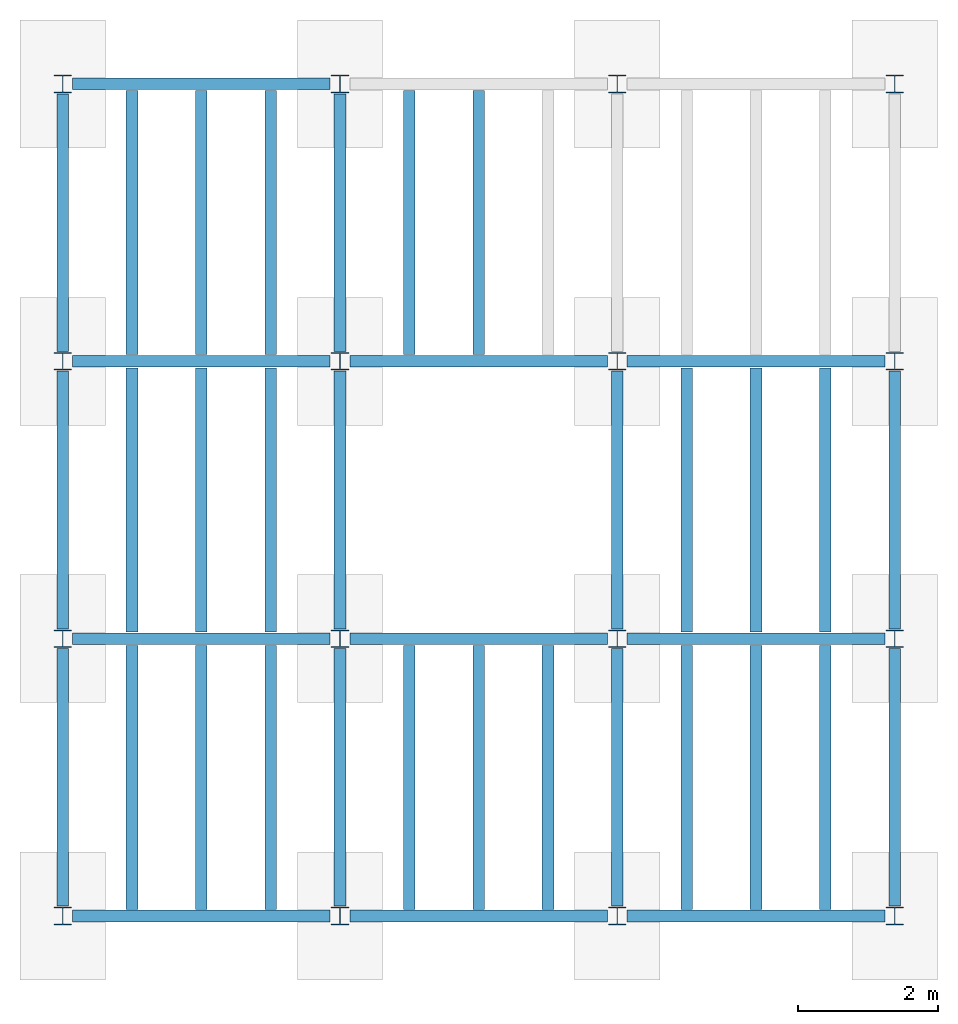
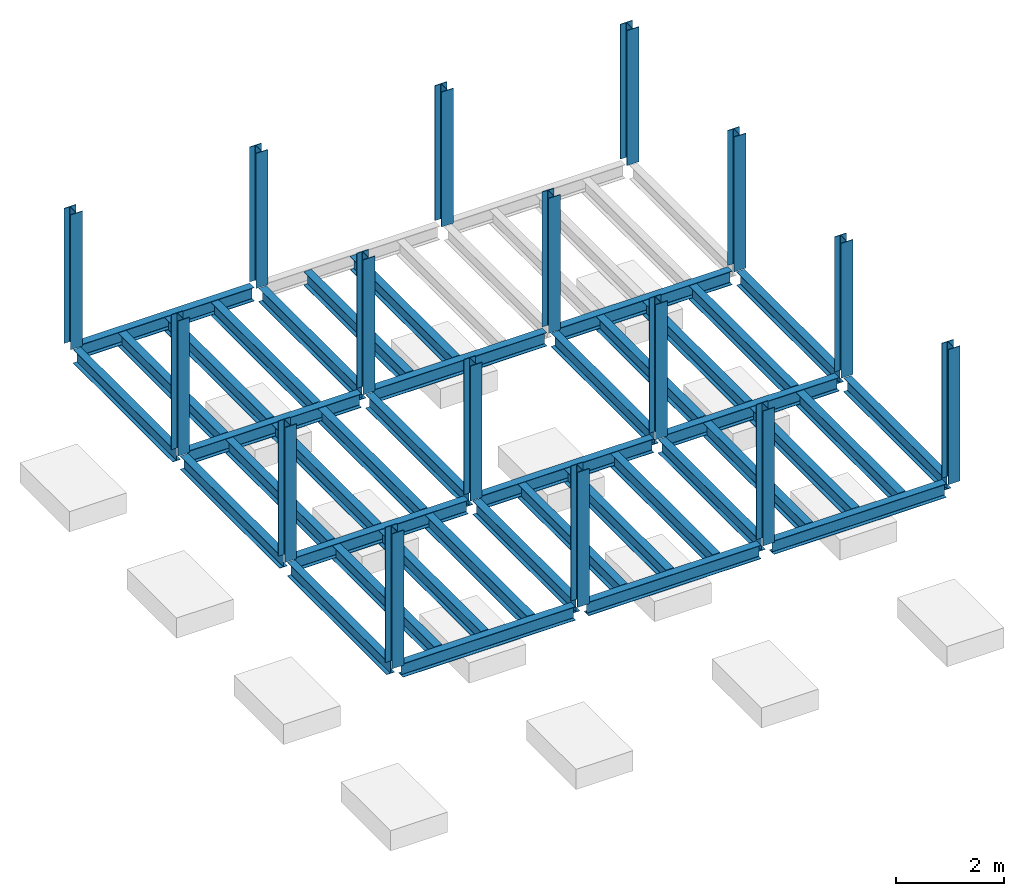
# One storey, part 1 of 2: 40 beams, 16 columns, 7 elements without a shape of their own.
"""IFC4 building model written with IfcOpenShell, lengths in feet."""

import ifcopenshell
import ifcopenshell.guid

model = None  # the IFC model being written
_history = None  # IfcOwnerHistory: only IFC2X3 demands one
_inside = {}  # id of a spatial element -> (the spatial element, [elements in it])
_under = {}  # id of a project, library or spatial element -> (it, [spatial elements below it])
_declared = {}  # id of a project -> (the project, [libraries it declares])
_typed = {}  # id of a type object -> (the type object, [elements of that type])
_made_of = {}  # id of a material, layer set ... -> (it, [elements and type objects made of it])


def new_model(schema):
    """Start an empty IFC model of exactly this schema.

    Asked for "IFC4X3", IfcOpenShell would pick the latest addendum, in which some entities
    have other attributes; the version numbers below select the first issue.
    IFC2X3 requires an IfcOwnerHistory on every rooted entity: one is made here for all.
    """
    global model, _history
    if schema == "IFC4X3":
        model = ifcopenshell.file(schema_version=(4, 3, 0, 0))
    else:
        model = ifcopenshell.file(schema=schema)
    _inside.clear()
    _under.clear()
    _declared.clear()
    _typed.clear()
    _made_of.clear()
    _history = None
    if model.schema == "IFC2X3":
        org = make("IfcOrganization", Name="unknown")
        user = make(
            "IfcPersonAndOrganization",
            ThePerson=make("IfcPerson", FamilyName="unknown"),
            TheOrganization=org,
        )
        app = make(
            "IfcApplication",
            ApplicationDeveloper=org,
            Version="unknown",
            ApplicationFullName="unknown",
            ApplicationIdentifier="unknown",
        )
        _history = make(
            "IfcOwnerHistory",
            OwningUser=user,
            OwningApplication=app,
            ChangeAction="ADDED",
            CreationDate=0,
        )
    return model


def make(cls, **values):
    """One entity of the class cls with the attributes given. An attribute that is None is left unset."""
    return model.create_entity(
        cls, **{name: value for name, value in values.items() if value is not None}
    )


def entity(cls, *values):
    """Any entity or typed value of the class cls, its attributes in the order of the schema. None: left unset."""
    e = model.create_entity(cls)
    for i, value in enumerate(values):
        if value is not None:
            e[i] = value
    return e


def rooted(cls, **values):
    """An entity with a GlobalId (a new one), such as an element, a storey or a relation."""
    return make(cls, GlobalId=ifcopenshell.guid.new(), OwnerHistory=_history, **values)


def si_unit(unit_type, name, prefix=None):
    """IfcSIUnit, for example si_unit("LENGTHUNIT", "METRE", prefix="MILLI")."""
    return make("IfcSIUnit", UnitType=unit_type, Prefix=prefix, Name=name)


def converted_unit(unit_type, name, factor, base, dimensions=None, offset=None):
    """IfcConversionBasedUnit, such as the inch: factor (a typed value) times the base unit."""
    return make(
        "IfcConversionBasedUnit"
        if offset is None
        else "IfcConversionBasedUnitWithOffset",
        ConversionOffset=offset,
        Dimensions=None
        if dimensions is None
        else entity("IfcDimensionalExponents", *dimensions),
        UnitType=unit_type,
        Name=name,
        ConversionFactor=make(
            "IfcMeasureWithUnit", ValueComponent=factor, UnitComponent=base
        ),
    )


def derived_unit(unit_type, elements):
    """IfcDerivedUnit: a product of units, each with its exponent."""
    return make(
        "IfcDerivedUnit",
        Elements=[
            make("IfcDerivedUnitElement", Unit=unit, Exponent=power)
            for unit, power in elements
        ],
        UnitType=unit_type,
    )


def assignment(units):
    """IfcUnitAssignment: the units of a project."""
    return None if units is None else make("IfcUnitAssignment", Units=units)


def point(xyz):
    """IfcCartesianPoint."""
    return None if xyz is None else make("IfcCartesianPoint", Coordinates=xyz)


def direction(xyz):
    """IfcDirection."""
    return None if xyz is None else make("IfcDirection", DirectionRatios=xyz)


def frame(location, z_axis=None, x_axis=None):
    """IfcAxis2Placement3D, a coordinate frame: its origin and axes. An axis left out is left unset."""
    return make(
        "IfcAxis2Placement3D",
        Location=point(location),
        Axis=direction(z_axis),
        RefDirection=direction(x_axis),
    )


def origin():
    """The frame at (0, 0, 0) with its axes left unset."""
    return frame((0.0, 0.0, 0.0))


def place(relative_to, where):
    """IfcLocalPlacement: puts the frame where relative to a parent placement (None: the world)."""
    return make(
        "IfcLocalPlacement", PlacementRelTo=relative_to, RelativePlacement=where
    )


def context(
    kind, dimensions, precision=None, world=None, true_north=None, identifier=None
):
    """IfcGeometricRepresentationContext, for example the 3D "Model" context."""
    return make(
        "IfcGeometricRepresentationContext",
        ContextIdentifier=identifier,
        ContextType=kind,
        CoordinateSpaceDimension=dimensions,
        Precision=precision,
        WorldCoordinateSystem=world,
        TrueNorth=true_north,
    )


def subcontext(parent, identifier, kind, view, scale=None):
    """IfcGeometricRepresentationSubContext, for example "Body" below "Model"."""
    return make(
        "IfcGeometricRepresentationSubContext",
        ContextIdentifier=identifier,
        ContextType=kind,
        ParentContext=parent,
        TargetScale=scale,
        TargetView=view,
    )


def project(units=None, contexts=None):
    """IfcProject with its units and contexts."""
    return rooted(
        "IfcProject",
        Name="project",
        RepresentationContexts=contexts,
        UnitsInContext=assignment(units),
    )


def spatial(cls, under=None, at=None, **own):
    """A site, building, storey or space (cls), placed at a placement, below another one or the project."""
    s = rooted(cls, ObjectPlacement=at, **own)
    if under is not None:
        _under.setdefault(under.id(), (under, []))[1].append(s)
    return s


def point_list(points):
    """IfcCartesianPointList2D or 3D."""
    cls = (
        "IfcCartesianPointList2D" if len(points[0]) == 2 else "IfcCartesianPointList3D"
    )
    return make(cls, CoordList=points)


def line(*indices):
    """IfcLineIndex: a straight run through numbered points of an indexed curve."""
    return model.create_entity("IfcLineIndex", indices)


def arc(*indices):
    """IfcArcIndex: an arc through three numbered points of an indexed curve."""
    return model.create_entity("IfcArcIndex", indices)


def indexed_curve(points, segments=None, self_intersect=None):
    """IfcIndexedPolyCurve: lines and arcs through numbered points (the first is 1)."""
    return make(
        "IfcIndexedPolyCurve",
        Points=point_list(points),
        Segments=segments,
        SelfIntersect=self_intersect,
    )


def outline(outer, holes=None, kind="AREA"):
    """IfcArbitraryClosedProfileDef: a profile drawn as a closed curve; with holes, ...WithVoids."""
    if holes is None:
        return make("IfcArbitraryClosedProfileDef", ProfileType=kind, OuterCurve=outer)
    return make(
        "IfcArbitraryProfileDefWithVoids",
        ProfileType=kind,
        OuterCurve=outer,
        InnerCurves=holes,
    )


def extrude(swept, where, along, depth):
    """IfcExtrudedAreaSolid: the profile swept, set in the frame where, extruded along a direction by depth."""
    return make(
        "IfcExtrudedAreaSolid",
        SweptArea=swept,
        Position=where,
        ExtrudedDirection=direction(along),
        Depth=depth,
    )


def shape(context_of_items, identifier, shape_type, items):
    """IfcShapeRepresentation: the items that make up one representation, for example the "Body"."""
    return make(
        "IfcShapeRepresentation",
        ContextOfItems=context_of_items,
        RepresentationIdentifier=identifier,
        RepresentationType=shape_type,
        Items=items,
    )


def source(mapping_origin, context_of_items, identifier, shape_type, items):
    """IfcRepresentationMap: a shape defined once, which mapped items show again and again."""
    return make(
        "IfcRepresentationMap",
        MappingOrigin=mapping_origin,
        MappedRepresentation=shape(context_of_items, identifier, shape_type, items),
    )


def transform(
    local_origin,
    x_axis=None,
    y_axis=None,
    z_axis=None,
    scale=None,
    scale2=None,
    scale3=None,
    uniform=True,
):
    """IfcCartesianTransformationOperator3D, or its non-uniform kind. x_axis, y_axis, z_axis: its Axis1, 2, 3."""
    if uniform:
        return make(
            "IfcCartesianTransformationOperator3D",
            Axis1=direction(x_axis),
            Axis2=direction(y_axis),
            LocalOrigin=point(local_origin),
            Scale=scale,
            Axis3=direction(z_axis),
        )
    return make(
        "IfcCartesianTransformationOperator3DnonUniform",
        Axis1=direction(x_axis),
        Axis2=direction(y_axis),
        LocalOrigin=point(local_origin),
        Scale=scale,
        Axis3=direction(z_axis),
        Scale2=scale2,
        Scale3=scale3,
    )


def mapped(mapping_source, mapping_target):
    """IfcMappedItem: shows the shape of a source again, moved by a transform."""
    return make(
        "IfcMappedItem", MappingSource=mapping_source, MappingTarget=mapping_target
    )


def material(Name=None, Category=None):
    """IfcMaterial."""
    return make("IfcMaterial", Name=Name, Category=Category)


def made_of(thing, what):
    """Note that an element or type object is made of a material, layer set ...; save() writes the relation."""
    if what is not None:
        _made_of.setdefault(what.id(), (what, []))[1].append(thing)
    return thing


def type_object(cls, material=None, **own):
    """A type object (cls), such as IfcWallType, which elements share."""
    return made_of(rooted(cls, **own), material)


def type_shapes(of_type, sources):
    """Give a type object the sources (RepresentationMaps) that its elements show as mapped items."""
    of_type.RepresentationMaps = sources


def element(
    cls,
    number,
    at=None,
    inside=None,
    cuts=None,
    type_object=None,
    material=None,
    context=None,
    identifier="Body",
    shape_type=None,
    held_by="IfcProductDefinitionShape",
    body=None,
    shapes=None,
    **own,
):
    """One element of the class cls, such as IfcWall. Its Tag is "e" and its number.

    at: its placement. inside: the storey or other place that contains it. cuts: it is an
    opening in that element (IfcRelVoidsElement). A single representation is given by context,
    identifier, shape_type and body (its items); several are given by shapes. held_by: the class
    of the entity that holds the representations. save() writes the other relations.
    """
    e = rooted(cls, Tag="e%d" % number, ObjectPlacement=at, **own)
    if body is not None:
        shapes = [shape(context, identifier, shape_type, body)]
    if shapes is not None:
        e.Representation = make(held_by, Representations=shapes)
    if inside is not None:
        _inside.setdefault(inside.id(), (inside, []))[1].append(e)
    if cuts is not None:
        rooted(
            "IfcRelVoidsElement", RelatingBuildingElement=cuts, RelatedOpeningElement=e
        )
    if type_object is not None:
        _typed.setdefault(type_object.id(), (type_object, []))[1].append(e)
    return made_of(e, material)


def aggregate(whole, parts):
    """IfcRelAggregates: a whole, such as a stair, and the parts it consists of."""
    return rooted("IfcRelAggregates", RelatingObject=whole, RelatedObjects=parts)


def save(model, path):
    """Write the relations noted so far, then the file.

    IfcRelAggregates (storeys below a building ...), IfcRelContainedInSpatialStructure (elements
    in a storey), IfcRelDefinesByType, IfcRelAssociatesMaterial and IfcRelDeclares: one each for
    every whole, place, type object, material and project.
    """
    for whole, parts in _under.values():
        aggregate(whole, parts)
    for where, things in _inside.values():
        rooted(
            "IfcRelContainedInSpatialStructure",
            RelatedElements=things,
            RelatingStructure=where,
        )
    for kind, things in _typed.values():
        rooted("IfcRelDefinesByType", RelatedObjects=things, RelatingType=kind)
    for what, things in _made_of.values():
        rooted("IfcRelAssociatesMaterial", RelatedObjects=things, RelatingMaterial=what)
    for by, libraries in _declared.values():
        rooted("IfcRelDeclares", RelatingContext=by, RelatedDefinitions=libraries)
    model.write(path)


model = new_model("IFC4")

# Units and contexts
model_context = context("Model", 3, precision=0.0001, world=origin(), true_north=direction((6.123233995736766e-17, 1.0)))
plan_context = context("Plan", 3, precision=0.0001, world=origin(), true_north=direction((6.123233995736766e-17, 1.0)))
body_context = subcontext(model_context, "Body", "Model", "MODEL_VIEW")
ifc_project = project(units=[converted_unit("LENGTHUNIT", "FOOT", entity("IfcLengthMeasure", 0.3048), si_unit("LENGTHUNIT", "METRE"), dimensions=[1, 0, 0, 0, 0, 0, 0]), converted_unit("AREAUNIT", "SQUARE FOOT", entity("IfcAreaMeasure", 0.09290304), si_unit("AREAUNIT", "SQUARE_METRE"), dimensions=[2, 0, 0, 0, 0, 0, 0]), converted_unit("PLANEANGLEUNIT", "DEGREE", entity("IfcPlaneAngleMeasure", 0.017453292519943278), si_unit("PLANEANGLEUNIT", "RADIAN"), dimensions=[0, 0, 0, 0, 0, 0, 0]), converted_unit("VOLUMEUNIT", "CUBIC FOOT", entity("IfcVolumeMeasure", 0.028316846592000004), si_unit("VOLUMEUNIT", "CUBIC_METRE"), dimensions=[3, 0, 0, 0, 0, 0, 0]), si_unit("PRESSUREUNIT", "PASCAL"), derived_unit("MASSDENSITYUNIT", [(si_unit("MASSUNIT", "GRAM", prefix="KILO"), 1), (si_unit("LENGTHUNIT", "METRE"), -3)]), derived_unit("VAPORPERMEABILITYUNIT", [(si_unit("LENGTHUNIT", "METRE"), -1), (si_unit("TIMEUNIT", "SECOND"), 1)]), derived_unit("USERDEFINED", [(si_unit("MASSUNIT", "GRAM", prefix="KILO"), 1), (si_unit("LENGTHUNIT", "METRE"), 3), (si_unit("TIMEUNIT", "SECOND"), -3), (si_unit("ELECTRICCURRENTUNIT", "AMPERE"), -2)]), derived_unit("MODULUSOFELASTICITYUNIT", [(si_unit("MASSUNIT", "GRAM", prefix="KILO"), 1), (si_unit("LENGTHUNIT", "METRE"), -1), (si_unit("TIMEUNIT", "SECOND"), -2)]), derived_unit("THERMALEXPANSIONCOEFFICIENTUNIT", [(si_unit("THERMODYNAMICTEMPERATUREUNIT", "KELVIN"), -1)]), derived_unit("SPECIFICHEATCAPACITYUNIT", [(si_unit("TIMEUNIT", "SECOND"), -2), (si_unit("THERMODYNAMICTEMPERATUREUNIT", "KELVIN"), -1), (si_unit("LENGTHUNIT", "METRE"), 2)]), derived_unit("THERMALCONDUCTANCEUNIT", [(si_unit("MASSUNIT", "GRAM", prefix="KILO"), 1), (si_unit("TIMEUNIT", "SECOND"), -3), (si_unit("THERMODYNAMICTEMPERATUREUNIT", "KELVIN"), -1), (si_unit("LENGTHUNIT", "METRE"), 1)])], contexts=[model_context, plan_context])

# Site, building, storey
site_placement = place(None, origin())
site = spatial("IfcSite", under=ifc_project, at=site_placement, CompositionType="ELEMENT")
building_placement = place(site_placement, origin())
building = spatial("IfcBuilding", under=site, at=building_placement, CompositionType="ELEMENT")
storey_placement = place(building_placement, frame((0.0, 0.0, 9.875000000001839)))
storey = spatial("IfcBuildingStorey", under=building, at=storey_placement, Name="STR 02", CompositionType="ELEMENT", Elevation=9.875000000001839)

# Columns
ifc_material = material(Name="Steel ASTM A992", Category="Metal")
column_type = type_object("IfcColumnType", Name="W10X49", PredefinedType="COLUMN", material=ifc_material)
shared_shape_1 = source(origin(), body_context, "Body", "SweptSolid", [
    extrude(outline(indexed_curve([(-0.41666666666666663, -0.4166666666666676), (0.41666666666666663, -0.4166666666666676), (0.41666666666666663, -0.3699999999999996), (0.055833333333333846, -0.3699999999999996), (0.02637055078389421, -0.35779611588277277), (0.014166666666666636, -0.32833333333333287), (0.01416666666666665, 0.32833333333333303), (0.026370550783893467, 0.3577961158827727), (0.05583333333333332, 0.3700000000000003), (0.41666666666666663, 0.3700000000000003), (0.41666666666666663, 0.4166666666666656), (-0.41666666666666663, 0.4166666666666656), (-0.41666666666666663, 0.3700000000000003), (-0.05583333333333365, 0.3700000000000003), (-0.02637055078389416, 0.3577961158827734), (-0.014166666666666685, 0.32833333333333387), (-0.014166666666666685, -0.32833333333333264), (-0.026370550783893578, -0.3577961158827721), (-0.055833333333333374, -0.3699999999999996), (-0.41666666666666663, -0.3699999999999996)], segments=[line(1, 2, 3, 4), arc(4, 5, 6), line(6, 7), arc(7, 8, 9), line(9, 10, 11, 12, 13, 14), arc(14, 15, 16), line(16, 17), arc(17, 18, 19), line(19, 20, 1)], self_intersect=False)), frame((0.0, 0.0, 9.875000000001839), z_axis=(0.0, 0.0, 1.0), x_axis=(-1.0, 0.0, 0.0)), (0.0, 0.0, 1.0), 9.999999999998161),
])
type_shapes(column_type, [shared_shape_1])
for number, where, z_axis, x_axis, name in (
    (1, (0.0, 39.0, -9.875000000001839), (0.0, 0.0, 1.0), (-1.0, 0.0, 0.0), "W10X49"),
    (2, (13.0, 0.0, -9.875000000001839), (0.0, 0.0, 1.0), (-1.0, 0.0, 0.0), "W10X49"),
    (3, (13.0, 13.0, -9.875000000001839), (0.0, 0.0, 1.0), (-1.0, 0.0, 0.0), "W10X49"),
    (4, (13.0, 26.0, -9.875000000001839), (0.0, 0.0, 1.0), (-1.0, 0.0, 0.0), "W10X49"),
    (5, (13.0, 39.0, -9.875000000001839), (0.0, 0.0, 1.0), (-1.0, 0.0, 0.0), "W10X49"),
    (6, (26.0, 0.0, -9.875000000001839), (0.0, 0.0, 1.0), (-1.0, 0.0, 0.0), "W10X49"),
    (7, (26.0, 13.0, -9.875000000001839), (0.0, 0.0, 1.0), (-1.0, 0.0, 0.0), "W10X49"),
    (8, (26.0, 26.0, -9.875000000001839), (0.0, 0.0, 1.0), (-1.0, 0.0, 0.0), "W10X49"),
    (9, (26.0, 39.0, -9.875000000001839), (0.0, 0.0, 1.0), (-1.0, 0.0, 0.0), "W10X49"),
    (10, (39.0, 0.0, -9.875000000001839), (0.0, 0.0, 1.0), (-1.0, 0.0, 0.0), "W10X49"),
    (11, (39.0, 13.0, -9.875000000001839), (0.0, 0.0, 1.0), (-1.0, 0.0, 0.0), "W10X49"),
    (12, (39.0, 26.0, -9.875000000001839), (0.0, 0.0, 1.0), (-1.0, 0.0, 0.0), "W10X49"),
    (13, (39.0, 39.0, -9.875000000001839), (0.0, 0.0, 1.0), (-1.0, 0.0, 0.0), "W10X49"),
    (14, (0.0, 0.0, -9.875000000001839), (0.0, 0.0, 1.0), (-1.0, 0.0, 0.0), "W10X49"),
    (15, (0.0, 13.0, -9.875000000001839), (0.0, 0.0, 1.0), (-1.0, 0.0, 0.0), "W10X49"),
    (16, (0.0, 26.0, -9.875000000001839), (0.0, 0.0, 1.0), (-1.0, 0.0, 0.0), "W10X49"),
):
    element("IfcColumn", number, at=place(storey_placement, frame(where, z_axis=z_axis, x_axis=x_axis)), inside=storey, type_object=column_type, material=ifc_material, Name=name, ObjectType="W Shapes-Column:W10X49", PredefinedType="COLUMN", context=body_context, shape_type="MappedRepresentation", body=[
        mapped(shared_shape_1, transform((0.0, 0.0, 0.0), scale=1.0)),
    ])

# Beams
beam_type_1 = type_object("IfcBeamType", Name="W12X26", PredefinedType="JOIST", material=ifc_material)
shared_shape_2 = source(origin(), body_context, "Body", "SweptSolid", [
    extrude(outline(indexed_curve([(-0.27041666666666714, -0.47666666666666574), (-0.27041666666666714, -0.5083333333333351), (0.2704166666666669, -0.5083333333333351), (0.2704166666666669, -0.47666666666666574), (0.03458333333333309, -0.47666666666666574), (0.016905663803669493, -0.46934433619632937), (0.009583333333333202, -0.4516666666666659), (0.0095833333333332, 0.45166666666666705), (0.01690566380366948, 0.4693443361963307), (0.03458333333333325, 0.4766666666666671), (0.2704166666666669, 0.4766666666666671), (0.2704166666666669, 0.5083333333333312), (-0.2704166666666655, 0.5083333333333312), (-0.2704166666666655, 0.4766666666666671), (-0.034583333333333514, 0.47666666666666707), (-0.016905663803669865, 0.46934433619633054), (-0.009583333333333737, 0.45166666666666694), (-0.009583333333333735, -0.4516666666666658), (-0.01690566380367013, -0.4693443361963295), (-0.03458333333333368, -0.47666666666666574)], segments=[line(1, 2, 3, 4, 5), arc(5, 6, 7), line(7, 8), arc(8, 9, 10), line(10, 11, 12, 13, 14, 15), arc(15, 16, 17), line(17, 18), arc(18, 19, 20), line(20, 1)], self_intersect=False)), frame((-6.103346456692914, 0.0, 0.0), z_axis=(-1.0, 0.0, 0.0), x_axis=(0.0, -1.0, 0.0)), (0.0, 0.0, -1.0), 12.083333333333323),
])
type_shapes(beam_type_1, [shared_shape_2])
for number, where, name in (
    (17, (6.561679790026306, 39.009583333333, -0.5083333333333329), "W12X26"),
    (18, (6.561679790026288, 26.0, -0.5083333333333329), "W12X26"),
    (19, (6.561679790026266, 13.0, -0.5083333333333329), "W12X26"),
):
    element("IfcBeam", number, at=place(storey_placement, frame(where)), inside=storey, type_object=beam_type_1, material=ifc_material, Name=name, ObjectType="W Shapes:W12X26", PredefinedType="JOIST", context=body_context, shape_type="MappedRepresentation", body=[
        mapped(shared_shape_2, transform((0.0, 0.0, 0.0), scale=1.0)),
    ])
for number, where, z_axis, x_axis, name in (
    (20, (39.0, 6.561679790026119, -0.5083333333333329), (0.0, 0.0, 1.0), (0.0, 1.0, 0.0), "W12X26"),
    (21, (26.0, 6.561679790026162, -0.5083333333333329), (0.0, 0.0, 1.0), (0.0, 1.0, 0.0), "W12X26"),
    (22, (13.0, 6.561679790026204, -0.5083333333333329), (0.0, 0.0, 1.0), (0.0, 1.0, 0.0), "W12X26"),
    (23, (0.0, 6.561679790026247, -0.5083333333333329), (0.0, 0.0, 1.0), (0.0, 1.0, 0.0), "W12X26"),
):
    element("IfcBeam", number, at=place(storey_placement, frame(where, z_axis=z_axis, x_axis=x_axis)), inside=storey, type_object=beam_type_1, material=ifc_material, Name=name, ObjectType="W Shapes:W12X26", PredefinedType="JOIST", context=body_context, shape_type="MappedRepresentation", body=[
        mapped(shared_shape_2, transform((0.0, 0.0, 0.0), scale=1.0)),
    ])
beam_type_2 = type_object("IfcBeamType", Name="W12X26", PredefinedType="JOIST", material=ifc_material)
shared_shape_3 = source(origin(), body_context, "Body", "SweptSolid", [
    extrude(outline(indexed_curve([(-0.27041666666666714, -0.47666666666666574), (-0.27041666666666714, -0.5083333333333351), (0.2704166666666669, -0.5083333333333351), (0.2704166666666669, -0.47666666666666574), (0.03458333333333309, -0.47666666666666574), (0.016905663803669493, -0.46934433619632937), (0.009583333333333202, -0.4516666666666659), (0.0095833333333332, 0.45166666666666705), (0.01690566380366948, 0.4693443361963307), (0.03458333333333325, 0.4766666666666671), (0.2704166666666669, 0.4766666666666671), (0.2704166666666669, 0.5083333333333312), (-0.2704166666666655, 0.5083333333333312), (-0.2704166666666655, 0.4766666666666671), (-0.034583333333333514, 0.47666666666666707), (-0.016905663803669865, 0.46934433619633054), (-0.009583333333333737, 0.45166666666666694), (-0.009583333333333735, -0.4516666666666658), (-0.01690566380367013, -0.4693443361963295), (-0.03458333333333368, -0.47666666666666574)], segments=[line(1, 2, 3, 4, 5), arc(5, 6, 7), line(7, 8), arc(8, 9, 10), line(10, 11, 12, 13, 14, 15), arc(15, 16, 17), line(17, 18), arc(18, 19, 20), line(20, 1)], self_intersect=False)), frame((-6.226706036745409, 0.0, 0.0), z_axis=(-1.0, 0.0, 0.0), x_axis=(0.0, -1.0, 0.0)), (0.0, 0.0, -1.0), 12.08333333333333),
])
type_shapes(beam_type_2, [shared_shape_3])
for number, where, name in (
    (24, (19.68503937007878, 26.0, -0.5083333333333329), "W12X26"),
    (25, (19.68503937007876, 13.0, -0.5083333333333329), "W12X26"),
):
    element("IfcBeam", number, at=place(storey_placement, frame(where)), inside=storey, type_object=beam_type_2, material=ifc_material, Name=name, ObjectType="W Shapes:W12X26", PredefinedType="JOIST", context=body_context, shape_type="MappedRepresentation", body=[
        mapped(shared_shape_3, transform((0.0, 0.0, 0.0), scale=1.0)),
    ])
for number, where, z_axis, x_axis, name in (
    (26, (39.0, 19.685039370078613, -0.5083333333333329), (0.0, 0.0, 1.0), (0.0, 1.0, 0.0), "W12X26"),
    (27, (26.0, 19.685039370078655, -0.5083333333333329), (0.0, 0.0, 1.0), (0.0, 1.0, 0.0), "W12X26"),
    (28, (13.0, 19.685039370078698, -0.5083333333333329), (0.0, 0.0, 1.0), (0.0, 1.0, 0.0), "W12X26"),
    (29, (0.0, 19.68503937007874, -0.5083333333333329), (0.0, 0.0, 1.0), (0.0, 1.0, 0.0), "W12X26"),
):
    element("IfcBeam", number, at=place(storey_placement, frame(where, z_axis=z_axis, x_axis=x_axis)), inside=storey, type_object=beam_type_2, material=ifc_material, Name=name, ObjectType="W Shapes:W12X26", PredefinedType="JOIST", context=body_context, shape_type="MappedRepresentation", body=[
        mapped(shared_shape_3, transform((0.0, 0.0, 0.0), scale=1.0)),
    ])
beam_type_3 = type_object("IfcBeamType", Name="W12X26", PredefinedType="JOIST", material=ifc_material)
shared_shape_4 = source(origin(), body_context, "Body", "SweptSolid", [
    extrude(outline(indexed_curve([(-0.27041666666666714, -0.47666666666666574), (-0.27041666666666714, -0.5083333333333351), (0.2704166666666669, -0.5083333333333351), (0.2704166666666669, -0.47666666666666574), (0.03458333333333309, -0.47666666666666574), (0.016905663803669493, -0.46934433619632937), (0.009583333333333202, -0.4516666666666659), (0.0095833333333332, 0.45166666666666705), (0.01690566380366948, 0.4693443361963307), (0.03458333333333325, 0.4766666666666671), (0.2704166666666669, 0.4766666666666671), (0.2704166666666669, 0.5083333333333312), (-0.2704166666666655, 0.5083333333333312), (-0.2704166666666655, 0.4766666666666671), (-0.034583333333333514, 0.47666666666666707), (-0.016905663803669865, 0.46934433619633054), (-0.009583333333333737, 0.45166666666666694), (-0.009583333333333735, -0.4516666666666658), (-0.01690566380367013, -0.4693443361963295), (-0.03458333333333368, -0.47666666666666574)], segments=[line(1, 2, 3, 4, 5), arc(5, 6, 7), line(7, 8), arc(8, 9, 10), line(10, 11, 12, 13, 14, 15), arc(15, 16, 17), line(17, 18), arc(18, 19, 20), line(20, 1)], self_intersect=False)), frame((-6.350065616797893, 0.0, 0.0), z_axis=(-1.0, 0.0, 0.0), x_axis=(0.0, -1.0, 0.0)), (0.0, 0.0, -1.0), 12.083333333333323),
])
type_shapes(beam_type_3, [shared_shape_4])
for number, where, name in (
    (30, (32.80839895013127, 26.0, -0.5083333333333329), "W12X26"),
    (31, (32.80839895013125, 13.0, -0.5083333333333329), "W12X26"),
    (32, (32.80839895013123, 0.0, -0.5083333333333329), "W12X26"),
):
    element("IfcBeam", number, at=place(storey_placement, frame(where)), inside=storey, type_object=beam_type_3, material=ifc_material, Name=name, ObjectType="W Shapes:W12X26", PredefinedType="JOIST", context=body_context, shape_type="MappedRepresentation", body=[
        mapped(shared_shape_4, transform((0.0, 0.0, 0.0), scale=1.0)),
    ])
for number, where, z_axis, x_axis, name in (
    (33, (13.0, 32.80839895013119, -0.5083333333333329), (0.0, 0.0, 1.0), (0.0, 1.0, 0.0), "W12X26"),
    (34, (0.0, 32.808398950131235, -0.5083333333333329), (0.0, 0.0, 1.0), (0.0, 1.0, 0.0), "W12X26"),
):
    element("IfcBeam", number, at=place(storey_placement, frame(where, z_axis=z_axis, x_axis=x_axis)), inside=storey, type_object=beam_type_3, material=ifc_material, Name=name, ObjectType="W Shapes:W12X26", PredefinedType="JOIST", context=body_context, shape_type="MappedRepresentation", body=[
        mapped(shared_shape_4, transform((0.0, 0.0, 0.0), scale=1.0)),
    ])
beam_type_4 = type_object("IfcBeamType", Name="W12X26", PredefinedType="JOIST", material=ifc_material)
shared_shape_5 = source(origin(), body_context, "Body", "SweptSolid", [
    extrude(outline(indexed_curve([(-0.27041666666666714, -0.47666666666666574), (-0.27041666666666714, -0.5083333333333351), (0.2704166666666669, -0.5083333333333351), (0.2704166666666669, -0.47666666666666574), (0.03458333333333309, -0.47666666666666574), (0.016905663803669493, -0.46934433619632937), (0.009583333333333202, -0.4516666666666659), (0.0095833333333332, 0.45166666666666705), (0.01690566380366948, 0.4693443361963307), (0.03458333333333325, 0.4766666666666671), (0.2704166666666669, 0.4766666666666671), (0.2704166666666669, 0.5083333333333312), (-0.2704166666666655, 0.5083333333333312), (-0.2704166666666655, 0.4766666666666671), (-0.034583333333333514, 0.47666666666666707), (-0.016905663803669865, 0.46934433619633054), (-0.009583333333333737, 0.45166666666666694), (-0.009583333333333735, -0.4516666666666658), (-0.01690566380367013, -0.4693443361963295), (-0.03458333333333368, -0.47666666666666574)], segments=[line(1, 2, 3, 4, 5), arc(5, 6, 7), line(7, 8), arc(8, 9, 10), line(10, 11, 12, 13, 14, 15), arc(15, 16, 17), line(17, 18), arc(18, 19, 20), line(20, 1)], self_intersect=False)), frame((-6.165026246719207, 0.0, 0.0), z_axis=(-1.0, 0.0, 0.0), x_axis=(0.0, -1.0, 0.0)), (0.0, 0.0, -1.0), 12.08333333333333),
])
type_shapes(beam_type_4, [shared_shape_5])
beam_1_placement = place(storey_placement, frame((19.623359580052536, 0.0, -0.5083333333333329)))
element("IfcBeam", 35, at=beam_1_placement, inside=storey, type_object=beam_type_4, material=ifc_material, Name="W12X26", ObjectType="W Shapes:W12X26", PredefinedType="JOIST", context=body_context, shape_type="MappedRepresentation", body=[
    mapped(shared_shape_5, transform((0.0, 0.0, 0.0), scale=1.0)),
])

# Assembly, beams
assembly_1_placement = place(storey_placement, origin())
assembly_1 = element("IfcElementAssembly", 36, at=assembly_1_placement, inside=storey, Name="Structural Framing System", ObjectType="Structural Beam System:Structural Framing System", AssemblyPlace="NOTDEFINED", PredefinedType="BEAM_GRID")
beam_type_5 = type_object("IfcBeamType", Name="W12X26", PredefinedType="JOIST", material=ifc_material)
shared_shape_6 = source(origin(), body_context, "Body", "SweptSolid", [
    extrude(outline(indexed_curve([(-0.27041666666666714, -0.47666666666666574), (-0.27041666666666714, -0.5083333333333351), (0.2704166666666669, -0.5083333333333351), (0.2704166666666669, -0.47666666666666574), (0.03458333333333309, -0.47666666666666574), (0.016905663803669493, -0.46934433619632937), (0.009583333333333202, -0.4516666666666659), (0.0095833333333332, 0.45166666666666705), (0.01690566380366948, 0.4693443361963307), (0.03458333333333325, 0.4766666666666671), (0.2704166666666669, 0.4766666666666671), (0.2704166666666669, 0.5083333333333312), (-0.2704166666666655, 0.5083333333333312), (-0.2704166666666655, 0.4766666666666671), (-0.034583333333333514, 0.47666666666666707), (-0.016905663803669865, 0.46934433619633054), (-0.009583333333333737, 0.45166666666666694), (-0.009583333333333735, -0.4516666666666658), (-0.01690566380367013, -0.4693443361963295), (-0.03458333333333368, -0.47666666666666574)], segments=[line(1, 2, 3, 4, 5), arc(5, 6, 7), line(7, 8), arc(8, 9, 10), line(10, 11, 12, 13, 14, 15), arc(15, 16, 17), line(17, 18), arc(18, 19, 20), line(20, 1)], self_intersect=False)), frame((-6.187916666666566, 0.0, 0.0), z_axis=(-1.0, 0.0, 0.0), x_axis=(0.0, -1.0, 0.0)), (0.0, 0.0, -1.0), 12.375833333333075),
])
type_shapes(beam_type_5, [shared_shape_6])
beam_2_placement = place(assembly_1_placement, frame((3.250000000000031, 6.499999999999793, -0.5083333333333329), z_axis=(0.0, 0.0, 1.0), x_axis=(0.0, 1.0, 0.0)))
beam_2 = element("IfcBeam", 37, at=beam_2_placement, type_object=beam_type_5, material=ifc_material, Name="W12X26", ObjectType="W Shapes:W12X26", PredefinedType="JOIST", context=body_context, shape_type="MappedRepresentation", body=[
    mapped(shared_shape_6, transform((0.0, 0.0, 0.0), scale=1.0)),
])
beam_3_placement = place(assembly_1_placement, frame((6.5000000000000515, 6.49999999999978, -0.5083333333333329), z_axis=(0.0, 0.0, 1.0), x_axis=(0.0, 1.0, 0.0)))
beam_3 = element("IfcBeam", 38, at=beam_3_placement, type_object=beam_type_5, material=ifc_material, Name="W12X26", ObjectType="W Shapes:W12X26", PredefinedType="JOIST", context=body_context, shape_type="MappedRepresentation", body=[
    mapped(shared_shape_6, transform((0.0, 0.0, 0.0), scale=1.0)),
])
beam_4_placement = place(assembly_1_placement, frame((9.750000000000073, 6.499999999999771, -0.5083333333333329), z_axis=(0.0, 0.0, 1.0), x_axis=(0.0, 1.0, 0.0)))
beam_4 = element("IfcBeam", 39, at=beam_4_placement, type_object=beam_type_5, material=ifc_material, Name="W12X26", ObjectType="W Shapes:W12X26", PredefinedType="JOIST", context=body_context, shape_type="MappedRepresentation", body=[
    mapped(shared_shape_6, transform((0.0, 0.0, 0.0), scale=1.0)),
])
aggregate(assembly_1, [beam_2, beam_3, beam_4])

assembly_2_placement = place(storey_placement, origin())
assembly_2 = element("IfcElementAssembly", 40, at=assembly_2_placement, inside=storey, Name="Structural Framing System", ObjectType="Structural Beam System:Structural Framing System", AssemblyPlace="NOTDEFINED", PredefinedType="BEAM_GRID")
beam_5_placement = place(assembly_2_placement, frame((3.2500000000000515, 19.49999999999968, -0.5083333333333329), z_axis=(0.0, 0.0, 1.0), x_axis=(0.0, 1.0, 0.0)))
beam_5 = element("IfcBeam", 41, at=beam_5_placement, type_object=beam_type_5, material=ifc_material, Name="W12X26", ObjectType="W Shapes:W12X26", PredefinedType="JOIST", context=body_context, shape_type="MappedRepresentation", body=[
    mapped(shared_shape_6, transform((0.0, 0.0, 0.0), scale=1.0)),
])
beam_6_placement = place(assembly_2_placement, frame((6.500000000000073, 19.499999999999666, -0.5083333333333329), z_axis=(0.0, 0.0, 1.0), x_axis=(0.0, 1.0, 0.0)))
beam_6 = element("IfcBeam", 42, at=beam_6_placement, type_object=beam_type_5, material=ifc_material, Name="W12X26", ObjectType="W Shapes:W12X26", PredefinedType="JOIST", context=body_context, shape_type="MappedRepresentation", body=[
    mapped(shared_shape_6, transform((0.0, 0.0, 0.0), scale=1.0)),
])
beam_7_placement = place(assembly_2_placement, frame((9.750000000000094, 19.49999999999966, -0.5083333333333329), z_axis=(0.0, 0.0, 1.0), x_axis=(0.0, 1.0, 0.0)))
beam_7 = element("IfcBeam", 43, at=beam_7_placement, type_object=beam_type_5, material=ifc_material, Name="W12X26", ObjectType="W Shapes:W12X26", PredefinedType="JOIST", context=body_context, shape_type="MappedRepresentation", body=[
    mapped(shared_shape_6, transform((0.0, 0.0, 0.0), scale=1.0)),
])
aggregate(assembly_2, [beam_5, beam_6, beam_7])

assembly_3_placement = place(storey_placement, origin())
assembly_3 = element("IfcElementAssembly", 44, at=assembly_3_placement, inside=storey, Name="Structural Framing System", ObjectType="Structural Beam System:Structural Framing System", AssemblyPlace="NOTDEFINED", PredefinedType="BEAM_GRID")
beam_8_placement = place(assembly_3_placement, frame((16.250000000000096, 6.499999999999792, -0.5083333333333329), z_axis=(0.0, 0.0, 1.0), x_axis=(0.0, 1.0, 0.0)))
beam_8 = element("IfcBeam", 45, at=beam_8_placement, type_object=beam_type_5, material=ifc_material, Name="W12X26", ObjectType="W Shapes:W12X26", PredefinedType="JOIST", context=body_context, shape_type="MappedRepresentation", body=[
    mapped(shared_shape_6, transform((0.0, 0.0, 0.0), scale=1.0)),
])
beam_9_placement = place(assembly_3_placement, frame((19.500000000000096, 6.49999999999978, -0.5083333333333329), z_axis=(0.0, 0.0, 1.0), x_axis=(0.0, 1.0, 0.0)))
beam_9 = element("IfcBeam", 46, at=beam_9_placement, type_object=beam_type_5, material=ifc_material, Name="W12X26", ObjectType="W Shapes:W12X26", PredefinedType="JOIST", context=body_context, shape_type="MappedRepresentation", body=[
    mapped(shared_shape_6, transform((0.0, 0.0, 0.0), scale=1.0)),
])
beam_10_placement = place(assembly_3_placement, frame((22.7500000000001, 6.499999999999771, -0.5083333333333329), z_axis=(0.0, 0.0, 1.0), x_axis=(0.0, 1.0, 0.0)))
beam_10 = element("IfcBeam", 47, at=beam_10_placement, type_object=beam_type_5, material=ifc_material, Name="W12X26", ObjectType="W Shapes:W12X26", PredefinedType="JOIST", context=body_context, shape_type="MappedRepresentation", body=[
    mapped(shared_shape_6, transform((0.0, 0.0, 0.0), scale=1.0)),
])
aggregate(assembly_3, [beam_8, beam_9, beam_10])

assembly_4_placement = place(storey_placement, origin())
assembly_4 = element("IfcElementAssembly", 48, at=assembly_4_placement, inside=storey, Name="Structural Framing System", ObjectType="Structural Beam System:Structural Framing System", AssemblyPlace="NOTDEFINED", PredefinedType="BEAM_GRID")
beam_11_placement = place(assembly_4_placement, frame((16.25000000000014, 32.499999999999645, -0.5083333333333329), z_axis=(0.0, 0.0, 1.0), x_axis=(0.0, 1.0, 0.0)))
beam_11 = element("IfcBeam", 49, at=beam_11_placement, type_object=beam_type_5, material=ifc_material, Name="W12X26", ObjectType="W Shapes:W12X26", PredefinedType="JOIST", context=body_context, shape_type="MappedRepresentation", body=[
    mapped(shared_shape_6, transform((0.0, 0.0, 0.0), scale=1.0)),
])
beam_12_placement = place(assembly_4_placement, frame((19.50000000000014, 32.49999999999963, -0.5083333333333329), z_axis=(0.0, 0.0, 1.0), x_axis=(0.0, 1.0, 0.0)))
beam_12 = element("IfcBeam", 50, at=beam_12_placement, type_object=beam_type_5, material=ifc_material, Name="W12X26", ObjectType="W Shapes:W12X26", PredefinedType="JOIST", context=body_context, shape_type="MappedRepresentation", body=[
    mapped(shared_shape_6, transform((0.0, 0.0, 0.0), scale=1.0)),
])
aggregate(assembly_4, [beam_11, beam_12])

assembly_5_placement = place(storey_placement, origin())
assembly_5 = element("IfcElementAssembly", 51, at=assembly_5_placement, inside=storey, Name="Structural Framing System", ObjectType="Structural Beam System:Structural Framing System", AssemblyPlace="NOTDEFINED", PredefinedType="BEAM_GRID")
beam_13_placement = place(assembly_5_placement, frame((29.250000000000096, 6.49999999999975, -0.5083333333333329), z_axis=(0.0, 0.0, 1.0), x_axis=(0.0, 1.0, 0.0)))
beam_13 = element("IfcBeam", 52, at=beam_13_placement, type_object=beam_type_5, material=ifc_material, Name="W12X26", ObjectType="W Shapes:W12X26", PredefinedType="JOIST", context=body_context, shape_type="MappedRepresentation", body=[
    mapped(shared_shape_6, transform((0.0, 0.0, 0.0), scale=1.0)),
])
beam_14_placement = place(assembly_5_placement, frame((32.5000000000001, 6.499999999999737, -0.5083333333333329), z_axis=(0.0, 0.0, 1.0), x_axis=(0.0, 1.0, 0.0)))
beam_14 = element("IfcBeam", 53, at=beam_14_placement, type_object=beam_type_5, material=ifc_material, Name="W12X26", ObjectType="W Shapes:W12X26", PredefinedType="JOIST", context=body_context, shape_type="MappedRepresentation", body=[
    mapped(shared_shape_6, transform((0.0, 0.0, 0.0), scale=1.0)),
])
beam_15_placement = place(assembly_5_placement, frame((35.750000000000085, 6.499999999999728, -0.5083333333333329), z_axis=(0.0, 0.0, 1.0), x_axis=(0.0, 1.0, 0.0)))
beam_15 = element("IfcBeam", 54, at=beam_15_placement, type_object=beam_type_5, material=ifc_material, Name="W12X26", ObjectType="W Shapes:W12X26", PredefinedType="JOIST", context=body_context, shape_type="MappedRepresentation", body=[
    mapped(shared_shape_6, transform((0.0, 0.0, 0.0), scale=1.0)),
])
aggregate(assembly_5, [beam_13, beam_14, beam_15])

assembly_6_placement = place(storey_placement, origin())
assembly_6 = element("IfcElementAssembly", 55, at=assembly_6_placement, inside=storey, Name="Structural Framing System", ObjectType="Structural Beam System:Structural Framing System", AssemblyPlace="NOTDEFINED", PredefinedType="BEAM_GRID")
beam_16_placement = place(assembly_6_placement, frame((29.25000000000012, 19.499999999999595, -0.5083333333333329), z_axis=(0.0, 0.0, 1.0), x_axis=(0.0, 1.0, 0.0)))
beam_16 = element("IfcBeam", 56, at=beam_16_placement, type_object=beam_type_5, material=ifc_material, Name="W12X26", ObjectType="W Shapes:W12X26", PredefinedType="JOIST", context=body_context, shape_type="MappedRepresentation", body=[
    mapped(shared_shape_6, transform((0.0, 0.0, 0.0), scale=1.0)),
])
beam_17_placement = place(assembly_6_placement, frame((32.500000000000114, 19.49999999999958, -0.5083333333333329), z_axis=(0.0, 0.0, 1.0), x_axis=(0.0, 1.0, 0.0)))
beam_17 = element("IfcBeam", 57, at=beam_17_placement, type_object=beam_type_5, material=ifc_material, Name="W12X26", ObjectType="W Shapes:W12X26", PredefinedType="JOIST", context=body_context, shape_type="MappedRepresentation", body=[
    mapped(shared_shape_6, transform((0.0, 0.0, 0.0), scale=1.0)),
])
beam_18_placement = place(assembly_6_placement, frame((35.750000000000114, 19.499999999999574, -0.5083333333333329), z_axis=(0.0, 0.0, 1.0), x_axis=(0.0, 1.0, 0.0)))
beam_18 = element("IfcBeam", 58, at=beam_18_placement, type_object=beam_type_5, material=ifc_material, Name="W12X26", ObjectType="W Shapes:W12X26", PredefinedType="JOIST", context=body_context, shape_type="MappedRepresentation", body=[
    mapped(shared_shape_6, transform((0.0, 0.0, 0.0), scale=1.0)),
])
aggregate(assembly_6, [beam_16, beam_17, beam_18])

assembly_7_placement = place(storey_placement, origin())
assembly_7 = element("IfcElementAssembly", 59, at=assembly_7_placement, inside=storey, Name="Structural Framing System", ObjectType="Structural Beam System:Structural Framing System", AssemblyPlace="NOTDEFINED", PredefinedType="BEAM_GRID")
beam_type_6 = type_object("IfcBeamType", Name="W12X26", PredefinedType="JOIST", material=ifc_material)
shared_shape_7 = source(origin(), body_context, "Body", "SweptSolid", [
    extrude(outline(indexed_curve([(-0.27041666666666714, -0.47666666666666574), (-0.27041666666666714, -0.5083333333333351), (0.2704166666666669, -0.5083333333333351), (0.2704166666666669, -0.47666666666666574), (0.03458333333333309, -0.47666666666666574), (0.016905663803669486, -0.46934433619632937), (0.009583333333333202, -0.4516666666666659), (0.0095833333333332, 0.45166666666666705), (0.016905663803669476, 0.4693443361963307), (0.03458333333333325, 0.4766666666666671), (0.2704166666666669, 0.4766666666666671), (0.2704166666666669, 0.5083333333333312), (-0.2704166666666655, 0.5083333333333312), (-0.2704166666666655, 0.4766666666666671), (-0.034583333333333514, 0.47666666666666707), (-0.016905663803669875, 0.46934433619633054), (-0.009583333333333737, 0.45166666666666694), (-0.009583333333333735, -0.4516666666666658), (-0.016905663803670125, -0.4693443361963295), (-0.03458333333333368, -0.47666666666666574)], segments=[line(1, 2, 3, 4, 5), arc(5, 6, 7), line(7, 8), arc(8, 9, 10), line(10, 11, 12, 13, 14, 15), arc(15, 16, 17), line(17, 18), arc(18, 19, 20), line(20, 1)], self_intersect=False)), frame((-6.192708333333386, 0.0, 0.0), z_axis=(-1.0, 0.0, 0.0), x_axis=(0.0, -1.0, 0.0)), (0.0, 0.0, -1.0), 12.385416666666718),
])
type_shapes(beam_type_6, [shared_shape_7])
beam_19_placement = place(assembly_7_placement, frame((3.250000000000073, 32.50479166666635, -0.5083333333333329), z_axis=(0.0, 0.0, 1.0), x_axis=(0.0, 1.0, 0.0)))
beam_19 = element("IfcBeam", 60, at=beam_19_placement, type_object=beam_type_6, material=ifc_material, Name="W12X26", ObjectType="W Shapes:W12X26", PredefinedType="JOIST", context=body_context, shape_type="MappedRepresentation", body=[
    mapped(shared_shape_7, transform((0.0, 0.0, 0.0), scale=1.0)),
])
beam_20_placement = place(assembly_7_placement, frame((6.500000000000094, 32.504791666666335, -0.5083333333333329), z_axis=(0.0, 0.0, 1.0), x_axis=(0.0, 1.0, 0.0)))
beam_20 = element("IfcBeam", 61, at=beam_20_placement, type_object=beam_type_6, material=ifc_material, Name="W12X26", ObjectType="W Shapes:W12X26", PredefinedType="JOIST", context=body_context, shape_type="MappedRepresentation", body=[
    mapped(shared_shape_7, transform((0.0, 0.0, 0.0), scale=1.0)),
])
beam_21_placement = place(assembly_7_placement, frame((9.750000000000115, 32.50479166666632, -0.5083333333333329), z_axis=(0.0, 0.0, 1.0), x_axis=(0.0, 1.0, 0.0)))
beam_21 = element("IfcBeam", 62, at=beam_21_placement, type_object=beam_type_6, material=ifc_material, Name="W12X26", ObjectType="W Shapes:W12X26", PredefinedType="JOIST", context=body_context, shape_type="MappedRepresentation", body=[
    mapped(shared_shape_7, transform((0.0, 0.0, 0.0), scale=1.0)),
])
aggregate(assembly_7, [beam_19, beam_20, beam_21])

# Beam
beam_type_7 = type_object("IfcBeamType", Name="W12X26", PredefinedType="JOIST", material=ifc_material)
shared_shape_8 = source(origin(), body_context, "Body", "SweptSolid", [
    extrude(outline(indexed_curve([(0.47666666666666574, -0.2704166666666672), (0.5083333333333351, -0.2704166666666672), (0.5083333333333351, 0.27041666666666686), (0.47666666666666574, 0.27041666666666686), (0.47666666666666574, 0.03458333333333307), (0.46934433619632937, 0.016905663803669473), (0.4516666666666659, 0.00958333333333318), (-0.45166666666666705, 0.00958333333333318), (-0.4693443361963307, 0.01690566380366946), (-0.4766666666666671, 0.03458333333333323), (-0.4766666666666671, 0.27041666666666686), (-0.5083333333333312, 0.27041666666666686), (-0.5083333333333312, -0.27041666666666553), (-0.4766666666666671, -0.27041666666666553), (-0.47666666666666707, -0.034583333333333535), (-0.46934433619633054, -0.016905663803669885), (-0.45166666666666694, -0.00958333333333376), (0.4516666666666658, -0.009583333333333756), (0.4693443361963295, -0.01690566380367015), (0.47666666666666574, -0.0345833333333337)], segments=[line(1, 2, 3, 4, 5), arc(5, 6, 7), line(7, 8), arc(8, 9, 10), line(10, 11, 12, 13, 14, 15), arc(15, 16, 17), line(17, 18), arc(18, 19, 20), line(20, 1)], self_intersect=False)), frame((-6.041666666666633, 0.0, 0.0), z_axis=(1.0, 0.0, 0.0), x_axis=(0.0, 0.0, -1.0)), (0.0, 0.0, 1.0), 12.083333333333323),
])
type_shapes(beam_type_7, [shared_shape_8])
beam_22_placement = place(storey_placement, frame((6.500000000000021, 0.0, -0.5083333333333329), z_axis=(0.0, 0.0, 1.0), x_axis=(-1.0, 0.0, 0.0)))
element("IfcBeam", 63, at=beam_22_placement, inside=storey, type_object=beam_type_7, material=ifc_material, Name="W12X26", ObjectType="W Shapes:W12X26", PredefinedType="JOIST", context=body_context, shape_type="MappedRepresentation", body=[
    mapped(shared_shape_8, transform((0.0, 0.0, 0.0), scale=1.0)),
])

save(model, "model.ifc")
